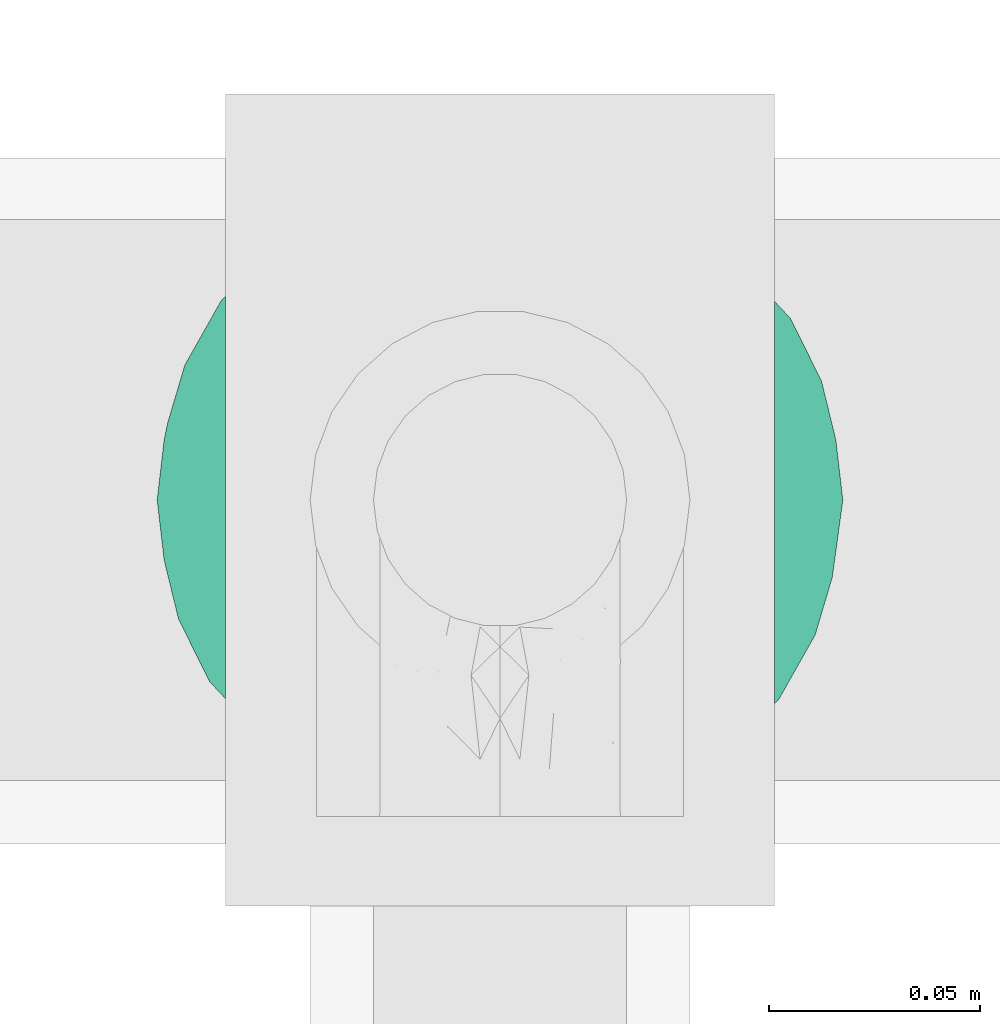
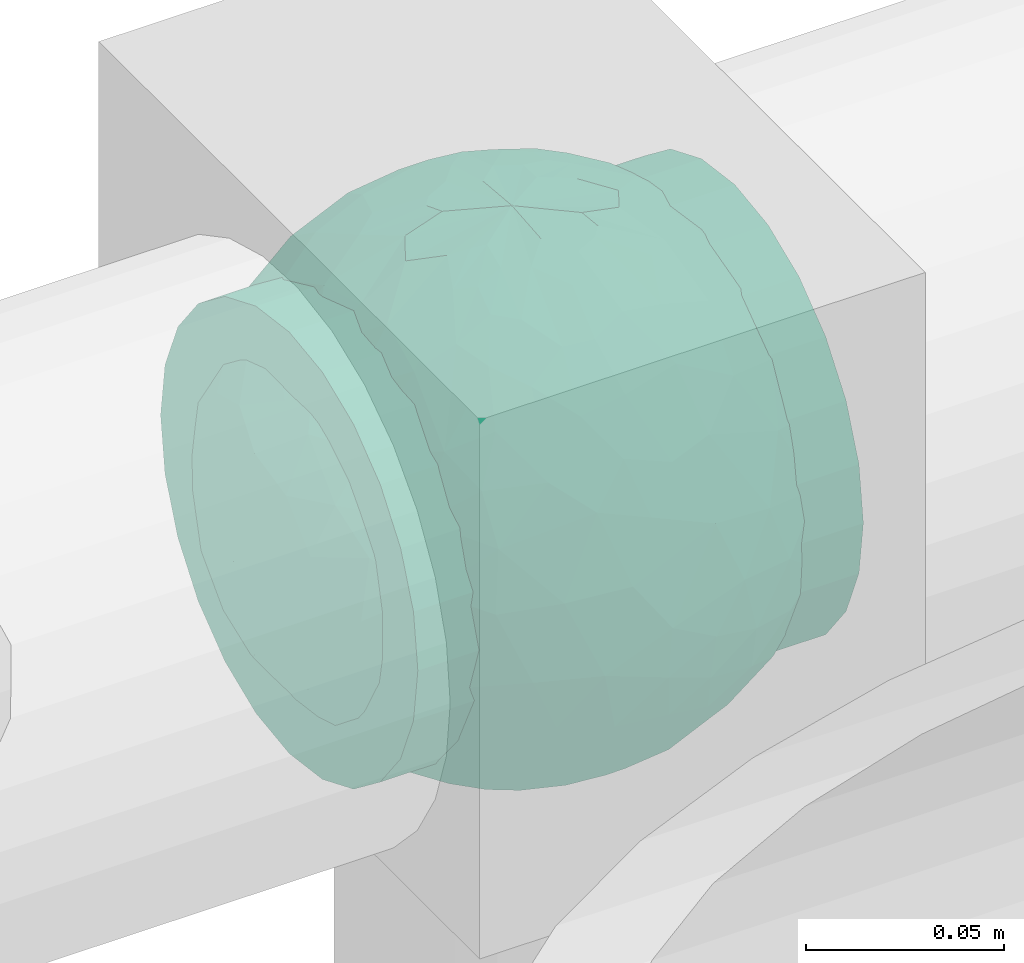
# One storey, part 713 of 827: 1 flow fitting.
"""IFC2X3 building model written with IfcOpenShell, lengths in millimetres."""

from ifc_helpers import new_model, entity, si_unit, converted_unit, derived_unit, direction, frame, origin, place, context, subcontext, project, spatial, faceted_brep, source, transform, mapped, material, material_list, type_object, type_shapes, element, save


model = new_model("IFC2X3")

# Units and contexts
model_context = context("Model", 3, precision=0.01, world=origin(), true_north=direction((6.12303176911189e-17, 1.0)))
body_context = subcontext(model_context, "Body", "Model", "MODEL_VIEW")
ifc_project = project(units=[si_unit("LENGTHUNIT", "METRE", prefix="MILLI"), si_unit("AREAUNIT", "SQUARE_METRE"), si_unit("VOLUMEUNIT", "CUBIC_METRE"), converted_unit("PLANEANGLEUNIT", "DEGREE", entity("IfcRatioMeasure", 0.0174532925199433), si_unit("PLANEANGLEUNIT", "RADIAN"), dimensions=[0, 0, 0, 0, 0, 0, 0]), si_unit("MASSUNIT", "GRAM", prefix="KILO"), derived_unit("MASSDENSITYUNIT", [(si_unit("MASSUNIT", "GRAM", prefix="KILO"), 1), (si_unit("LENGTHUNIT", "METRE"), -3)]), derived_unit("MOMENTOFINERTIAUNIT", [(si_unit("LENGTHUNIT", "METRE"), 4)]), si_unit("TIMEUNIT", "SECOND"), si_unit("FREQUENCYUNIT", "HERTZ"), si_unit("THERMODYNAMICTEMPERATUREUNIT", "DEGREE_CELSIUS"), derived_unit("THERMALTRANSMITTANCEUNIT", [(si_unit("MASSUNIT", "GRAM", prefix="KILO"), 1), (si_unit("THERMODYNAMICTEMPERATUREUNIT", "KELVIN"), -1), (si_unit("TIMEUNIT", "SECOND"), -3)]), derived_unit("VOLUMETRICFLOWRATEUNIT", [(si_unit("LENGTHUNIT", "METRE"), 3), (si_unit("TIMEUNIT", "SECOND"), -1)]), derived_unit("MASSFLOWRATEUNIT", [(si_unit("MASSUNIT", "GRAM", prefix="KILO"), 1), (si_unit("TIMEUNIT", "SECOND"), -1)]), derived_unit("ROTATIONALFREQUENCYUNIT", [(si_unit("TIMEUNIT", "SECOND"), -1)]), si_unit("ELECTRICCURRENTUNIT", "AMPERE"), si_unit("ELECTRICVOLTAGEUNIT", "VOLT"), si_unit("POWERUNIT", "WATT"), si_unit("FORCEUNIT", "NEWTON", prefix="KILO"), si_unit("ILLUMINANCEUNIT", "LUX"), si_unit("LUMINOUSFLUXUNIT", "LUMEN"), si_unit("LUMINOUSINTENSITYUNIT", "CANDELA"), derived_unit("USERDEFINED", [(si_unit("MASSUNIT", "GRAM", prefix="KILO"), -1), (si_unit("LENGTHUNIT", "METRE"), -2), (si_unit("TIMEUNIT", "SECOND"), 3), (si_unit("LUMINOUSFLUXUNIT", "LUMEN"), 1)]), derived_unit("LINEARVELOCITYUNIT", [(si_unit("LENGTHUNIT", "METRE"), 1), (si_unit("TIMEUNIT", "SECOND"), -1)]), si_unit("PRESSUREUNIT", "PASCAL"), derived_unit("USERDEFINED", [(si_unit("LENGTHUNIT", "METRE"), -2), (si_unit("MASSUNIT", "GRAM", prefix="KILO"), 1), (si_unit("TIMEUNIT", "SECOND"), -2)]), derived_unit("LINEARFORCEUNIT", [(si_unit("MASSUNIT", "GRAM", prefix="KILO"), 1), (si_unit("LENGTHUNIT", "METRE"), 1), (si_unit("TIMEUNIT", "SECOND"), -2), (si_unit("LENGTHUNIT", "METRE"), -1)]), derived_unit("PLANARFORCEUNIT", [(si_unit("MASSUNIT", "GRAM", prefix="KILO"), 1), (si_unit("LENGTHUNIT", "METRE"), 1), (si_unit("TIMEUNIT", "SECOND"), -2), (si_unit("LENGTHUNIT", "METRE"), -2)])], contexts=[model_context])

# Site, building, storey
site_placement = place(None, origin())
site = spatial("IfcSite", under=ifc_project, at=site_placement, CompositionType="ELEMENT")
building_placement = place(site_placement, origin())
building = spatial("IfcBuilding", under=site, at=building_placement, CompositionType="ELEMENT")
storey_placement = place(building_placement, frame((0.0, 0.0, 28200.0)))
storey = spatial("IfcBuildingStorey", under=building, at=storey_placement, Name="08", CompositionType="ELEMENT", Elevation=28200.0)

# Flow fitting
ifc_material_1 = material()
ifc_material_2 = material(Name="ADSK_")
ifc_material_list = material_list([ifc_material_1, ifc_material_2])
pipe_fitting_type = type_object("IfcPipeFittingType", Name="ADSK_2", PredefinedType="NOTDEFINED", material=ifc_material_list)
shared_shape = source(origin(), body_context, "Body", "Brep", [
    faceted_brep([(-65.0, 32.5, -56.29), (-65.0, 16.82, -62.79), (-65.0, 0.0, -65.0), (-65.0, -16.82, -62.79), (-65.0, -32.5, -56.29), (-65.0, -45.96, -45.96), (-65.0, -56.29, -32.5), (-65.0, -62.79, -16.82), (-65.0, -63.89, -8.41), (-65.0, -65.0, 0.0), (-65.0, -63.89, 8.41), (-65.0, -62.79, 16.82), (-65.0, -56.29, 32.5), (-65.0, -45.96, 45.96), (-65.0, -32.5, 56.29), (-65.0, -16.82, 62.79), (-65.0, 0.0, 65.0), (-65.0, 16.82, 62.79), (-65.0, 32.5, 56.29), (-65.0, 45.96, 45.96), (-65.0, 56.29, 32.5), (-65.0, 62.79, 16.82), (-65.0, 65.0, 0.0), (-65.0, 62.79, -16.82), (-65.0, 56.29, -32.5), (-65.0, 45.96, -45.96), (65.0, 0.0, -65.0), (65.0, 16.82, -62.79), (65.0, 32.5, -56.29), (65.0, 45.96, -45.96), (65.0, 56.29, -32.5), (65.0, 62.79, -16.82), (65.0, 65.0, 0.0), (65.0, 62.79, 16.82), (65.0, 56.29, 32.5), (65.0, 45.96, 45.96), (65.0, 32.5, 56.29), (65.0, 16.82, 62.79), (65.0, 0.0, 65.0), (65.0, -16.82, 62.79), (65.0, -32.5, 56.29), (65.0, -45.96, 45.96), (65.0, -56.29, 32.5), (65.0, -62.79, 16.82), (65.0, -63.89, 8.41), (65.0, -65.0, 0.0), (65.0, -63.89, -8.41), (65.0, -62.79, -16.82), (65.0, -56.29, -32.5), (65.0, -45.96, -45.96), (65.0, -32.5, -56.29), (65.0, -16.82, -62.79), (25.81, -64.3, 9.49), (27.5, -65.0, 0.0), (-27.5, -65.0, 0.0), (21.04, -62.54, 17.71), (4.82, -59.09, 27.07), (13.81, -60.49, 23.78), (9.32, -59.79, 25.43), (-25.81, -64.3, 9.48), (-26.66, -64.65, 4.74), (-21.05, -62.54, 17.7), (-13.81, -60.49, 23.78), (-9.32, -59.79, 25.43), (-4.83, -59.09, 27.07), (0.0, -59.09, 27.07), (26.66, -64.65, 4.74), (-25.81, -64.3, -9.48), (-26.66, -64.65, -4.74), (13.81, -60.49, -23.78), (9.32, -59.79, -25.43), (4.82, -59.09, -27.07), (25.81, -64.3, -9.49), (21.04, -62.54, -17.71), (26.66, -64.65, -4.74), (-4.83, -59.09, -27.07), (-9.32, -59.79, -25.43), (-13.81, -60.49, -23.78), (0.0, -59.09, -27.07), (-21.05, -62.54, -17.7), (0.0, -70.0, -27.5), (7.12, -70.0, -26.56), (13.75, -70.0, -23.82), (19.45, -70.0, -19.45), (23.82, -70.0, -13.75), (26.56, -70.0, -7.12), (27.5, -70.0, 0.0), (26.56, -70.0, 7.12), (23.82, -70.0, 13.75), (19.45, -70.0, 19.45), (13.75, -70.0, 23.82), (7.12, -70.0, 26.56), (0.0, -70.0, 27.5), (-7.12, -70.0, 26.56), (-13.75, -70.0, 23.82), (-19.45, -70.0, 19.45), (-23.82, -70.0, 13.75), (-26.56, -70.0, 7.12), (-27.5, -70.0, 0.0), (-26.56, -70.0, -7.12), (-23.82, -70.0, -13.75), (-19.45, -70.0, -19.45), (-13.75, -70.0, -23.82), (-7.12, -70.0, -26.56)], [[[0, 1, 2, 3, 4, 5, 6, 7, 8, 9, 10, 11, 12, 13, 14, 15, 16, 17, 18, 19, 20, 21, 22, 23, 24, 25]], [[26, 27, 28, 29, 30, 31, 32, 33, 34, 35, 36, 37, 38, 39, 40, 41, 42, 43, 44, 45, 46, 47, 48, 49, 50, 51]], [[44, 43, 52]], [[53, 45, 44]], [[9, 54, 10]], [[43, 55, 52]], [[56, 42, 12]], [[55, 43, 57]], [[42, 56, 58, 57]], [[42, 41, 13, 12]], [[57, 43, 42]], [[59, 11, 10]], [[10, 54, 60, 59]], [[59, 61, 11]], [[12, 62, 63, 64]], [[12, 11, 62]], [[12, 64, 65, 56]], [[62, 11, 61]], [[44, 52, 66, 53]], [[41, 40, 14, 13]], [[16, 15, 39, 38]], [[15, 14, 40, 39]], [[17, 16, 38, 37]], [[34, 33, 21, 20]], [[19, 18, 36, 35]], [[20, 19, 35, 34]], [[37, 36, 18, 17]], [[22, 21, 33, 32]], [[22, 32, 31, 23]], [[24, 30, 29, 25]], [[23, 31, 30, 24]], [[26, 51, 3, 2]], [[1, 0, 28, 27]], [[2, 1, 27, 26]], [[28, 0, 25, 29]], [[50, 4, 3, 51]], [[50, 49, 5, 4]], [[6, 5, 49, 48]], [[8, 67, 68, 54]], [[48, 69, 70, 71]], [[48, 47, 69]], [[6, 48, 71]], [[45, 53, 46]], [[8, 54, 9]], [[72, 73, 47]], [[46, 53, 74, 72]], [[47, 73, 69]], [[6, 75, 76, 77]], [[72, 47, 46]], [[77, 7, 6]], [[6, 71, 78, 75]], [[79, 67, 7]], [[67, 8, 7]], [[79, 7, 77]], [[80, 81, 82, 83, 84, 85, 86, 87, 88, 89, 90, 91, 92, 93, 94, 95, 96, 97, 98, 99, 100, 101, 102, 103]], [[97, 60, 98]], [[61, 96, 95]], [[97, 96, 59]], [[95, 94, 62]], [[97, 59, 60]], [[60, 54, 98]], [[59, 96, 61]], [[66, 52, 87]], [[93, 64, 63]], [[62, 61, 95]], [[92, 56, 65, 64]], [[90, 58, 91]], [[92, 64, 93]], [[56, 92, 91]], [[58, 90, 57]], [[55, 89, 88]], [[90, 89, 57]], [[52, 88, 87]], [[89, 55, 57]], [[56, 91, 58]], [[63, 62, 94]], [[86, 66, 87]], [[52, 55, 88]], [[66, 86, 53]], [[63, 94, 93]], [[85, 74, 86]], [[73, 84, 83]], [[85, 84, 72]], [[83, 82, 69]], [[85, 72, 74]], [[74, 53, 86]], [[72, 84, 73]], [[68, 67, 99]], [[81, 71, 70]], [[69, 73, 83]], [[80, 75, 78, 71]], [[102, 76, 103]], [[80, 71, 81]], [[75, 80, 103]], [[76, 102, 77]], [[79, 101, 100]], [[102, 101, 77]], [[67, 100, 99]], [[101, 79, 77]], [[75, 103, 76]], [[70, 69, 82]], [[98, 68, 99]], [[67, 79, 100]], [[68, 98, 54]], [[70, 82, 81]]]),
    faceted_brep([(-26.57, 76.36, -8.07), (-32.83, 71.49, -20.33), (-47.03, 64.85, -13.55), (22.24, -77.88, -6.48), (0.0, -81.25, 0.0), (14.57, -79.42, -9.02), (-19.55, 43.65, -65.68), (-6.7, 41.88, -69.3), (-15.5, 23.94, -76.08), (15.55, -78.16, 0.0), (20.63, -67.73, -39.86), (17.31, -55.39, -56.87), (33.39, -55.07, -49.54), (6.89, -77.99, -21.73), (13.76, -77.98, -18.22), (0.0, -79.9, -14.73), (-69.67, 30.72, -28.35), (-63.35, 45.14, -23.48), (-60.56, 38.81, -37.79), (-44.27, 66.26, 0.0), (8.9, -68.68, -42.49), (0.0, -57.53, -57.37), (-48.93, 45.14, -46.58), (-49.03, 57.11, -30.6), (-35.46, 62.54, -37.85), (76.18, -1.07, -28.23), (78.6, -12.72, -16.17), (71.53, -15.85, -35.12), (10.46, 67.82, -43.51), (0.0, 75.3, -30.53), (6.86, 78.01, -21.66), (-10.53, -67.73, -43.64), (0.0, -75.25, -30.63), (-6.89, -77.99, -21.73), (0.0, 81.25, 0.0), (15.55, 78.16, 0.0), (22.61, 77.77, -6.46), (-12.72, -56.34, -57.14), (-5.46, -45.53, -67.07), (44.37, 62.32, -27.38), (43.44, 67.56, -12.26), (56.18, 55.82, -18.18), (-13.79, 77.96, -18.26), (-25.89, 72.59, -25.72), (-16.58, 78.16, -14.76), (75.07, 31.09, 0.0), (74.86, 27.47, -15.59), (67.53, 42.93, -14.07), (13.79, 77.96, -18.26), (12.84, 79.64, -9.7), (21.38, 75.85, -19.79), (74.72, 15.85, -27.69), (79.59, 7.96, -14.27), (43.73, -67.56, -11.18), (57.45, -57.45, 0.0), (44.27, -66.26, 0.0), (63.35, -45.14, -23.48), (61.82, -51.54, -11.09), (49.12, -59.87, -24.59), (78.16, 15.55, 0.0), (50.83, -12.03, -62.24), (35.62, -9.55, -72.4), (43.7, 11.32, -67.56), (72.48, -29.04, -22.46), (-44.38, -62.32, -27.37), (-26.83, -74.87, -16.61), (-43.44, -67.56, -12.26), (-13.76, -77.98, -18.22), (-12.85, -79.64, -9.7), (-21.39, -75.84, -19.81), (-2.49, -31.04, -75.05), (8.59, -44.22, -67.62), (-74.72, -15.85, -27.69), (-68.67, -30.94, -30.47), (-74.55, -27.6, -16.8), (-75.07, 31.09, 0.0), (-71.41, 36.12, -14.04), (-75.88, 22.59, -18.27), (-22.61, -77.77, -6.46), (-16.87, -79.04, -8.34), (28.21, -26.53, -71.43), (13.03, -29.67, -74.51), (18.2, -9.78, -78.58), (-56.42, -55.66, -17.92), (6.0, 45.8, -66.84), (0.0, 57.69, -57.22), (-78.16, -15.55, 0.0), (-79.59, -7.96, -14.27), (32.83, -71.49, -20.33), (-15.55, -78.16, 0.0), (-20.62, 67.82, -39.72), (-33.11, 50.34, -54.51), (-61.82, 51.54, -11.09), (-66.26, 44.27, 0.0), (75.07, -31.09, 0.0), (66.26, -44.27, 0.0), (-6.86, 78.01, -21.66), (0.0, 79.92, -14.67), (26.82, 74.88, -16.61), (16.85, 79.04, -8.33), (-8.98, 69.99, -40.29), (38.78, -61.98, -35.46), (48.93, -45.14, -46.58), (55.26, -48.62, -34.41), (-71.53, 15.85, -35.12), (-78.76, 7.96, -18.29), (-17.06, 58.9, -53.31), (-15.55, 78.16, 0.0), (13.32, 55.85, -57.49), (21.86, 61.99, -47.75), (-15.13, 79.31, -9.05), (26.19, -72.28, -26.28), (17.27, -77.87, -15.49), (-29.57, -28.73, -70.02), (-26.25, -43.22, -63.6), (-42.18, -36.82, -58.88), (41.25, 41.74, -56.2), (54.79, 33.3, -49.91), (40.91, 28.53, -64.14), (38.98, -38.31, -60.12), (52.67, -28.88, -54.71), (68.84, 3.22, -43.04), (66.02, 21.29, -42.31), (-42.82, 33.53, -60.37), (-55.21, 10.46, -58.69), (-57.08, 27.98, -50.61), (-56.33, -15.85, -56.37), (-55.8, -33.3, -48.77), (-66.18, -20.5, -42.45), (31.09, 75.07, 0.0), (44.27, 66.26, 0.0), (57.45, 57.45, 0.0), (-31.09, -75.07, 0.0), (-57.45, -57.45, 0.0), (1.56, 67.82, -44.72), (-1.57, -67.73, -44.86), (22.55, 72.77, -28.25), (16.53, 72.17, -33.48), (-22.52, -72.77, -28.27), (-16.58, -72.47, -32.79), (28.96, -66.23, -37.11), (62.57, -34.08, -39.05), (62.37, -15.41, -49.74), (68.82, 31.09, -29.97), (-66.06, -1.38, -47.28), (-67.87, -42.27, -14.43), (29.1, 65.34, -38.54), (33.22, 68.08, -29.37), (46.02, 49.13, -45.5), (10.35, 15.34, -79.12), (0.0, 0.22, -81.25), (-29.12, -65.31, -38.57), (-22.07, -61.55, -48.23), (-33.19, -68.12, -29.33), (-46.02, -49.17, -45.45), (-34.11, 19.17, -71.21), (-23.02, 4.97, -77.76), (-40.38, 0.85, -70.5), (2.47, 31.35, -74.92), (16.3, 35.47, -71.26), (-13.73, -8.11, -79.67), (-28.12, -13.42, -75.04), (33.83, 54.01, -50.4), (26.1, 43.46, -63.49), (24.94, -42.3, -64.73), (-16.13, -35.64, -71.21), (0.28, -15.85, -79.69), (-13.57, -22.47, -76.89), (60.35, 45.14, -30.37), (-60.34, -45.14, -30.38), (-33.99, -54.1, -50.2), (-57.45, 57.45, 0.0), (-42.67, -18.04, -66.75), (-63.99, 15.14, -47.72), (-81.25, 0.0, 0.0), (-78.16, 15.55, 0.0), (-74.66, 0.0, -32.06), (-31.09, 75.07, 0.0), (31.09, -75.07, 0.0), (56.37, 15.85, -56.33), (28.0, 13.82, -75.01), (66.26, 44.27, 0.0), (81.25, 0.0, 0.0), (78.16, -15.55, 0.0), (-66.26, -44.27, 0.0), (-75.07, -31.09, 0.0), (-44.27, -66.26, 0.0), (26.57, 76.36, 8.07), (32.83, 71.49, 20.33), (47.03, 64.85, 13.55), (-22.24, -77.88, 6.48), (-14.57, -79.42, 9.02), (19.55, 43.65, 65.68), (6.7, 41.88, 69.3), (15.5, 23.94, 76.08), (-20.63, -67.73, 39.86), (-17.31, -55.39, 56.87), (-33.39, -55.07, 49.54), (-6.89, -77.99, 21.73), (-13.76, -77.98, 18.22), (0.0, -79.9, 14.73), (69.67, 30.72, 28.35), (63.35, 45.14, 23.48), (60.56, 38.81, 37.79), (-8.9, -68.68, 42.49), (0.0, -57.53, 57.37), (48.93, 45.14, 46.58), (49.03, 57.11, 30.6), (35.46, 62.54, 37.85), (-76.18, -1.07, 28.23), (-78.6, -12.72, 16.17), (-71.53, -15.85, 35.12), (-10.46, 67.82, 43.51), (0.0, 75.3, 30.53), (-6.86, 78.01, 21.66), (10.53, -67.73, 43.64), (0.0, -75.25, 30.63), (6.89, -77.99, 21.73), (-22.61, 77.77, 6.46), (12.72, -56.34, 57.14), (5.46, -45.53, 67.07), (-44.37, 62.32, 27.38), (-43.44, 67.56, 12.26), (-56.18, 55.82, 18.18), (13.79, 77.96, 18.26), (25.89, 72.59, 25.72), (16.58, 78.16, 14.76), (-74.86, 27.47, 15.59), (-67.53, 42.93, 14.07), (-13.79, 77.96, 18.26), (-12.84, 79.64, 9.7), (-21.38, 75.85, 19.79), (-74.72, 15.85, 27.69), (-79.59, 7.96, 14.27), (-43.73, -67.56, 11.18), (-63.35, -45.14, 23.48), (-61.82, -51.54, 11.09), (-49.12, -59.87, 24.59), (-50.83, -12.03, 62.24), (-35.62, -9.55, 72.4), (-43.7, 11.32, 67.56), (-72.48, -29.04, 22.46), (44.38, -62.32, 27.37), (26.83, -74.87, 16.61), (43.44, -67.56, 12.26), (13.76, -77.98, 18.22), (12.85, -79.64, 9.7), (21.39, -75.84, 19.81), (2.49, -31.04, 75.05), (-8.59, -44.22, 67.62), (74.72, -15.85, 27.69), (68.67, -30.94, 30.47), (74.55, -27.6, 16.8), (71.41, 36.12, 14.04), (75.88, 22.59, 18.27), (22.61, -77.77, 6.46), (16.87, -79.04, 8.34), (-28.21, -26.53, 71.43), (-13.03, -29.67, 74.51), (-18.2, -9.78, 78.58), (56.42, -55.66, 17.92), (-6.0, 45.8, 66.84), (0.0, 57.69, 57.22), (78.78, -14.01, 14.13), (-32.83, -71.49, 20.33), (20.62, 67.82, 39.72), (33.11, 50.34, 54.51), (61.82, 51.54, 11.09), (6.86, 78.01, 21.66), (0.0, 79.92, 14.67), (-26.82, 74.88, 16.61), (-16.85, 79.04, 8.33), (8.98, 69.99, 40.29), (-38.78, -61.98, 35.46), (-48.93, -45.14, 46.58), (-55.26, -48.62, 34.41), (71.53, 15.85, 35.12), (78.76, 7.96, 18.29), (17.06, 58.9, 53.31), (-13.32, 55.85, 57.49), (-21.86, 61.99, 47.75), (15.13, 79.31, 9.05), (-26.19, -72.28, 26.28), (-17.27, -77.87, 15.49), (29.57, -28.73, 70.02), (26.25, -43.22, 63.6), (42.18, -36.82, 58.88), (-41.25, 41.74, 56.2), (-54.79, 33.3, 49.91), (-40.91, 28.53, 64.14), (-38.98, -38.31, 60.12), (-52.67, -28.88, 54.71), (-68.84, 3.22, 43.04), (-66.02, 21.29, 42.31), (42.82, 33.53, 60.37), (55.21, 10.46, 58.69), (57.08, 27.98, 50.61), (56.33, -15.85, 56.37), (55.8, -33.3, 48.77), (66.18, -20.5, 42.45), (-1.56, 67.82, 44.72), (1.57, -67.73, 44.86), (-22.55, 72.77, 28.25), (-16.53, 72.17, 33.48), (22.52, -72.77, 28.27), (16.58, -72.47, 32.79), (-28.96, -66.23, 37.11), (-62.57, -34.08, 39.05), (-62.37, -15.41, 49.74), (-68.82, 31.09, 29.97), (66.06, -1.38, 47.28), (67.87, -42.27, 14.43), (-29.1, 65.34, 38.54), (-33.22, 68.08, 29.37), (-46.02, 49.13, 45.5), (-10.35, 15.34, 79.12), (0.0, 0.22, 81.25), (29.12, -65.31, 38.57), (22.07, -61.55, 48.23), (33.19, -68.12, 29.33), (46.02, -49.17, 45.45), (34.11, 19.17, 71.21), (23.02, 4.97, 77.76), (40.38, 0.85, 70.5), (-2.47, 31.35, 74.92), (-16.3, 35.47, 71.26), (13.73, -8.11, 79.67), (28.12, -13.42, 75.04), (-33.83, 54.01, 50.4), (-26.1, 43.46, 63.49), (-24.94, -42.3, 64.73), (16.13, -35.64, 71.21), (-0.28, -15.85, 79.69), (13.57, -22.47, 76.89), (-60.35, 45.14, 30.37), (60.34, -45.14, 30.38), (33.99, -54.1, 50.2), (42.67, -18.04, 66.75), (63.99, 15.14, 47.72), (74.66, 0.0, 32.06), (-56.37, 15.85, 56.33), (-28.0, 13.82, 75.01)], [[[0, 1, 2]], [[3, 4, 5]], [[6, 7, 8]], [[4, 3, 9]], [[10, 11, 12]], [[13, 14, 4]], [[13, 4, 15]], [[16, 17, 18]], [[19, 0, 2]], [[20, 21, 11]], [[22, 23, 24]], [[25, 26, 27]], [[28, 29, 30]], [[31, 32, 33]], [[34, 35, 36]], [[37, 38, 21]], [[39, 40, 41]], [[42, 43, 44]], [[45, 46, 47]], [[30, 34, 48]], [[49, 50, 48]], [[51, 46, 52]], [[53, 54, 55]], [[56, 57, 58]], [[46, 59, 52]], [[60, 61, 62]], [[27, 26, 63]], [[64, 65, 66]], [[67, 68, 69]], [[38, 70, 71]], [[72, 73, 74]], [[15, 33, 32]], [[75, 76, 77]], [[78, 65, 79]], [[80, 81, 82]], [[64, 66, 83]], [[84, 7, 85]], [[74, 86, 87]], [[88, 53, 3]], [[4, 89, 78]], [[24, 90, 91]], [[92, 76, 93]], [[94, 95, 63]], [[96, 34, 97]], [[36, 98, 99]], [[96, 42, 34]], [[96, 100, 90]], [[101, 102, 103]], [[77, 104, 105]], [[90, 106, 91]], [[34, 0, 107]], [[84, 85, 108]], [[109, 108, 28]], [[0, 110, 1]], [[14, 111, 112]], [[97, 30, 29]], [[39, 98, 40]], [[67, 33, 4]], [[113, 114, 115]], [[116, 117, 118]], [[119, 60, 120]], [[121, 122, 51]], [[123, 124, 125]], [[126, 127, 128]], [[129, 40, 36]], [[130, 131, 40]], [[132, 66, 78]], [[133, 83, 66]], [[97, 29, 96]], [[28, 108, 134]], [[100, 96, 29]], [[44, 34, 42]], [[15, 32, 13]], [[32, 31, 135]], [[20, 13, 32]], [[112, 4, 14]], [[48, 136, 137]], [[96, 90, 42]], [[90, 24, 43]], [[68, 67, 4]], [[67, 138, 139]], [[13, 10, 14]], [[140, 101, 111]], [[53, 58, 57]], [[141, 102, 120]], [[27, 142, 121]], [[46, 51, 143]], [[23, 2, 1]], [[125, 18, 22]], [[124, 126, 144]], [[73, 145, 74]], [[30, 137, 28]], [[28, 137, 109]], [[146, 147, 148]], [[149, 150, 8]], [[151, 152, 139]], [[152, 114, 37]], [[151, 153, 154]], [[155, 156, 157]], [[158, 84, 159]], [[156, 8, 150]], [[156, 160, 161]], [[155, 124, 123]], [[162, 116, 163]], [[119, 80, 60]], [[12, 102, 101]], [[81, 164, 71]], [[91, 123, 22]], [[100, 106, 90]], [[70, 38, 165]], [[81, 70, 166]], [[167, 113, 161]], [[156, 161, 157]], [[131, 47, 41]], [[36, 40, 98]], [[148, 39, 168]], [[146, 136, 147]], [[143, 117, 168]], [[146, 162, 109]], [[99, 34, 36]], [[133, 145, 83]], [[78, 66, 65]], [[154, 64, 169]], [[151, 138, 153]], [[115, 127, 126]], [[151, 170, 152]], [[79, 4, 78]], [[134, 100, 29]], [[85, 7, 106]], [[85, 106, 100]], [[91, 106, 6]], [[123, 6, 155]], [[91, 22, 24]], [[22, 18, 23]], [[43, 24, 1]], [[92, 17, 76]], [[1, 24, 23]], [[17, 2, 23]], [[92, 171, 2]], [[110, 0, 34]], [[6, 123, 91]], [[157, 161, 172]], [[144, 126, 128]], [[123, 125, 22]], [[124, 173, 125]], [[104, 16, 18]], [[18, 125, 173]], [[23, 18, 17]], [[105, 174, 175]], [[76, 17, 16]], [[105, 176, 87]], [[77, 175, 75]], [[176, 105, 104]], [[77, 76, 16]], [[76, 75, 93]], [[93, 171, 92]], [[177, 0, 19]], [[2, 17, 92]], [[104, 77, 16]], [[175, 77, 105]], [[3, 53, 178]], [[53, 88, 58]], [[88, 3, 5]], [[101, 58, 88]], [[56, 103, 141]], [[111, 101, 88]], [[101, 140, 12]], [[10, 20, 11]], [[119, 102, 12]], [[71, 70, 81]], [[119, 164, 80]], [[164, 12, 11]], [[80, 82, 61]], [[51, 25, 121]], [[119, 120, 102]], [[13, 20, 10]], [[20, 32, 135]], [[60, 142, 120]], [[56, 58, 103]], [[142, 141, 120]], [[63, 141, 27]], [[121, 60, 179]], [[141, 142, 27]], [[60, 121, 142]], [[122, 121, 179]], [[117, 122, 179]], [[143, 51, 122]], [[117, 179, 118]], [[168, 117, 148]], [[62, 118, 179]], [[159, 118, 180]], [[117, 143, 122]], [[143, 168, 47]], [[41, 47, 168]], [[47, 131, 181]], [[47, 46, 143]], [[46, 45, 59]], [[59, 182, 52]], [[26, 52, 182]], [[25, 51, 52]], [[26, 182, 183]], [[95, 57, 63]], [[26, 25, 52]], [[121, 25, 27]], [[94, 63, 26]], [[141, 63, 56]], [[53, 57, 54]], [[54, 57, 95]], [[63, 57, 56]], [[39, 41, 168]], [[41, 40, 131]], [[12, 164, 119]], [[164, 11, 71]], [[11, 21, 71]], [[38, 71, 21]], [[21, 135, 37]], [[38, 37, 165]], [[152, 37, 31]], [[165, 37, 114]], [[139, 31, 33]], [[151, 154, 170]], [[31, 139, 152]], [[67, 139, 33]], [[113, 165, 114]], [[167, 161, 160]], [[114, 170, 115]], [[172, 161, 113]], [[127, 115, 154]], [[172, 115, 126]], [[115, 172, 113]], [[157, 126, 124]], [[126, 157, 172]], [[124, 155, 157]], [[8, 156, 155]], [[160, 156, 150]], [[6, 8, 155]], [[8, 158, 149]], [[154, 169, 127]], [[128, 73, 72]], [[73, 127, 169]], [[176, 144, 128]], [[176, 128, 72]], [[173, 144, 104]], [[115, 170, 154]], [[114, 152, 170]], [[127, 73, 128]], [[73, 169, 145]], [[83, 145, 169]], [[145, 133, 184]], [[145, 185, 74]], [[74, 185, 86]], [[87, 86, 174]], [[105, 87, 174]], [[74, 87, 72]], [[64, 83, 169]], [[66, 132, 186]], [[167, 166, 70]], [[164, 81, 80]], [[149, 82, 150]], [[80, 61, 60]], [[82, 180, 61]], [[62, 180, 118]], [[112, 88, 5]], [[140, 14, 10]], [[166, 160, 150]], [[165, 167, 70]], [[150, 82, 166]], [[81, 166, 82]], [[167, 165, 113]], [[166, 167, 160]], [[88, 112, 111]], [[4, 112, 5]], [[144, 176, 104]], [[87, 176, 72]], [[101, 103, 58]], [[102, 141, 103]], [[60, 62, 179]], [[61, 180, 62]], [[14, 140, 111]], [[12, 140, 10]], [[48, 137, 30]], [[109, 137, 146]], [[162, 146, 148]], [[108, 85, 134]], [[109, 163, 108]], [[163, 159, 84]], [[116, 162, 148]], [[163, 109, 162]], [[163, 84, 108]], [[7, 84, 158]], [[118, 159, 163]], [[149, 159, 180]], [[8, 7, 158]], [[7, 6, 106]], [[117, 116, 148]], [[163, 116, 118]], [[98, 49, 99]], [[50, 49, 98]], [[34, 49, 48]], [[147, 98, 39]], [[136, 48, 50]], [[147, 39, 148]], [[137, 136, 146]], [[136, 50, 147]], [[98, 147, 50]], [[34, 99, 49]], [[65, 68, 79]], [[68, 65, 69]], [[153, 65, 64]], [[138, 67, 69]], [[153, 64, 154]], [[139, 138, 151]], [[138, 69, 153]], [[65, 153, 69]], [[4, 79, 68]], [[34, 30, 97]], [[4, 33, 15]], [[100, 134, 85]], [[29, 28, 134]], [[37, 135, 31]], [[20, 135, 21]], [[159, 149, 158]], [[82, 149, 180]], [[40, 129, 130]], [[186, 133, 66]], [[44, 1, 110]], [[90, 43, 42]], [[1, 44, 43]], [[34, 44, 110]], [[2, 171, 19]], [[0, 177, 107]], [[144, 173, 124]], [[18, 173, 104]], [[3, 178, 9]], [[55, 178, 53]], [[181, 45, 47]], [[94, 26, 183]], [[184, 185, 145]], [[35, 129, 36]], [[89, 132, 78]], [[187, 188, 189]], [[190, 4, 191]], [[192, 193, 194]], [[4, 190, 89]], [[195, 196, 197]], [[198, 199, 4]], [[198, 4, 200]], [[201, 202, 203]], [[130, 187, 189]], [[204, 205, 196]], [[206, 207, 208]], [[209, 210, 211]], [[212, 213, 214]], [[215, 216, 217]], [[34, 107, 218]], [[219, 220, 205]], [[221, 222, 223]], [[224, 225, 226]], [[75, 227, 228]], [[214, 34, 229]], [[230, 231, 229]], [[232, 227, 233]], [[234, 133, 186]], [[235, 236, 237]], [[227, 175, 233]], [[238, 239, 240]], [[211, 210, 241]], [[242, 243, 244]], [[245, 246, 247]], [[220, 248, 249]], [[250, 251, 252]], [[200, 217, 216]], [[45, 253, 254]], [[255, 243, 256]], [[257, 258, 259]], [[242, 244, 260]], [[261, 193, 262]], [[252, 183, 263]], [[264, 234, 190]], [[4, 9, 255]], [[208, 265, 266]], [[267, 253, 181]], [[185, 184, 241]], [[268, 34, 269]], [[218, 270, 271]], [[268, 224, 34]], [[268, 272, 265]], [[273, 274, 275]], [[254, 276, 277]], [[265, 278, 266]], [[34, 187, 35]], [[261, 262, 279]], [[280, 279, 212]], [[187, 281, 188]], [[199, 282, 283]], [[269, 214, 213]], [[221, 270, 222]], [[245, 217, 4]], [[284, 285, 286]], [[287, 288, 289]], [[290, 238, 291]], [[292, 293, 232]], [[294, 295, 296]], [[297, 298, 299]], [[177, 222, 218]], [[171, 223, 222]], [[178, 244, 255]], [[54, 260, 244]], [[269, 213, 268]], [[34, 230, 229]], [[212, 279, 300]], [[272, 268, 213]], [[226, 34, 224]], [[200, 216, 198]], [[216, 215, 301]], [[204, 198, 216]], [[229, 302, 303]], [[268, 265, 224]], [[265, 208, 225]], [[246, 245, 4]], [[245, 304, 305]], [[198, 195, 199]], [[306, 273, 282]], [[234, 237, 236]], [[307, 274, 291]], [[211, 308, 292]], [[227, 232, 309]], [[207, 189, 188]], [[296, 203, 206]], [[295, 297, 310]], [[251, 311, 252]], [[214, 303, 212]], [[212, 303, 280]], [[312, 313, 314]], [[315, 316, 194]], [[317, 318, 305]], [[318, 285, 219]], [[317, 319, 320]], [[321, 322, 323]], [[324, 261, 325]], [[322, 194, 316]], [[322, 326, 327]], [[321, 295, 294]], [[328, 287, 329]], [[290, 257, 238]], [[197, 274, 273]], [[258, 330, 249]], [[266, 294, 206]], [[272, 278, 265]], [[248, 220, 331]], [[258, 248, 332]], [[333, 284, 327]], [[322, 327, 323]], [[171, 228, 223]], [[218, 222, 270]], [[314, 221, 334]], [[312, 302, 313]], [[309, 288, 334]], [[312, 328, 280]], [[271, 34, 218]], [[54, 311, 260]], [[255, 244, 243]], [[320, 242, 335]], [[317, 304, 319]], [[286, 298, 297]], [[317, 336, 318]], [[256, 4, 255]], [[300, 272, 213]], [[262, 193, 278]], [[262, 278, 272]], [[266, 278, 192]], [[294, 192, 321]], [[266, 206, 208]], [[206, 203, 207]], [[225, 208, 188]], [[267, 202, 253]], [[188, 208, 207]], [[202, 189, 207]], [[267, 131, 189]], [[281, 187, 34]], [[192, 294, 266]], [[323, 327, 337]], [[310, 297, 299]], [[294, 296, 206]], [[295, 338, 296]], [[276, 201, 203]], [[203, 296, 338]], [[207, 203, 202]], [[277, 182, 59]], [[253, 202, 201]], [[263, 250, 252]], [[254, 59, 45]], [[339, 277, 276]], [[254, 253, 201]], [[253, 45, 181]], [[181, 131, 267]], [[129, 187, 130]], [[189, 202, 267]], [[276, 254, 201]], [[59, 254, 277]], [[190, 234, 132]], [[234, 264, 237]], [[272, 300, 262]], [[264, 190, 191]], [[273, 237, 264]], [[235, 275, 307]], [[282, 273, 264]], [[273, 306, 197]], [[195, 204, 196]], [[290, 274, 197]], [[249, 248, 258]], [[290, 330, 257]], [[330, 197, 196]], [[257, 259, 239]], [[232, 209, 292]], [[290, 291, 274]], [[198, 204, 195]], [[204, 216, 301]], [[238, 308, 291]], [[235, 237, 275]], [[308, 307, 291]], [[241, 307, 211]], [[292, 238, 340]], [[307, 308, 211]], [[238, 292, 308]], [[293, 292, 340]], [[288, 293, 340]], [[309, 232, 293]], [[288, 340, 289]], [[334, 288, 314]], [[240, 289, 340]], [[325, 289, 341]], [[288, 309, 293]], [[309, 334, 228]], [[223, 228, 334]], [[228, 171, 93]], [[228, 227, 309]], [[227, 75, 175]], [[175, 174, 233]], [[210, 233, 174]], [[209, 232, 233]], [[210, 174, 86]], [[184, 236, 241]], [[210, 209, 233]], [[292, 209, 211]], [[185, 241, 210]], [[307, 241, 235]], [[234, 236, 133]], [[133, 236, 184]], [[241, 236, 235]], [[221, 223, 334]], [[222, 177, 19]], [[197, 330, 290]], [[330, 196, 249]], [[196, 205, 249]], [[220, 249, 205]], [[205, 301, 219]], [[220, 219, 331]], [[318, 219, 215]], [[331, 219, 285]], [[305, 215, 217]], [[317, 320, 336]], [[215, 305, 318]], [[245, 305, 217]], [[284, 331, 285]], [[333, 327, 326]], [[285, 336, 286]], [[337, 327, 284]], [[298, 286, 320]], [[337, 286, 297]], [[286, 337, 284]], [[323, 297, 295]], [[297, 323, 337]], [[295, 321, 323]], [[194, 322, 321]], [[326, 322, 316]], [[192, 194, 321]], [[194, 324, 315]], [[320, 335, 298]], [[299, 251, 250]], [[251, 298, 335]], [[339, 310, 299]], [[339, 299, 250]], [[338, 310, 276]], [[286, 336, 320]], [[285, 318, 336]], [[298, 251, 299]], [[251, 335, 311]], [[260, 311, 335]], [[311, 54, 95]], [[311, 94, 252]], [[252, 94, 183]], [[182, 277, 263]], [[182, 263, 183]], [[339, 263, 277]], [[242, 260, 335]], [[244, 178, 55]], [[333, 332, 248]], [[330, 258, 257]], [[315, 259, 316]], [[257, 239, 238]], [[259, 341, 239]], [[240, 341, 289]], [[283, 264, 191]], [[306, 199, 195]], [[332, 326, 316]], [[331, 333, 248]], [[316, 259, 332]], [[258, 332, 259]], [[333, 331, 284]], [[332, 333, 326]], [[264, 283, 282]], [[4, 283, 191]], [[310, 339, 276]], [[263, 339, 250]], [[273, 275, 237]], [[274, 307, 275]], [[238, 240, 340]], [[239, 341, 240]], [[199, 306, 282]], [[197, 306, 195]], [[229, 303, 214]], [[280, 303, 312]], [[328, 312, 314]], [[279, 262, 300]], [[280, 329, 279]], [[329, 325, 261]], [[287, 328, 314]], [[329, 280, 328]], [[329, 261, 279]], [[193, 261, 324]], [[289, 325, 329]], [[315, 325, 341]], [[194, 193, 324]], [[193, 192, 278]], [[288, 287, 314]], [[329, 287, 289]], [[270, 230, 271]], [[231, 230, 270]], [[313, 270, 221]], [[302, 229, 231]], [[313, 221, 314]], [[303, 302, 312]], [[302, 231, 313]], [[270, 313, 231]], [[34, 271, 230]], [[243, 246, 256]], [[246, 243, 247]], [[319, 243, 242]], [[304, 245, 247]], [[319, 242, 320]], [[305, 304, 317]], [[304, 247, 319]], [[243, 319, 247]], [[4, 256, 246]], [[34, 214, 269]], [[4, 217, 200]], [[4, 199, 283]], [[213, 212, 300]], [[219, 301, 215]], [[204, 301, 205]], [[325, 315, 324]], [[259, 315, 341]], [[19, 171, 222]], [[55, 54, 244]], [[226, 188, 281]], [[265, 225, 224]], [[188, 226, 225]], [[34, 226, 281]], [[189, 131, 130]], [[187, 129, 35]], [[310, 338, 295]], [[203, 338, 276]], [[190, 132, 89]], [[186, 132, 234]], [[93, 75, 228]], [[185, 210, 86]], [[95, 94, 311]], [[107, 177, 218]], [[9, 178, 255]]]),
])
type_shapes(pipe_fitting_type, [shared_shape])
flow_fitting_placement = place(storey_placement, frame((59297.89, 18180.1, 2900.0), z_axis=(0.0, -1.0, 0.0), x_axis=(1.0, 0.0, 0.0)))
element("IfcFlowFitting", 1, at=flow_fitting_placement, inside=storey, type_object=pipe_fitting_type, material=ifc_material_list, Name="ADSK_2", ObjectType="ADSK_2", context=body_context, shape_type="MappedRepresentation", body=[
    mapped(shared_shape, transform((0.0, 0.0, 0.0), scale=1.0)),
])

save(model, "model.ifc")
